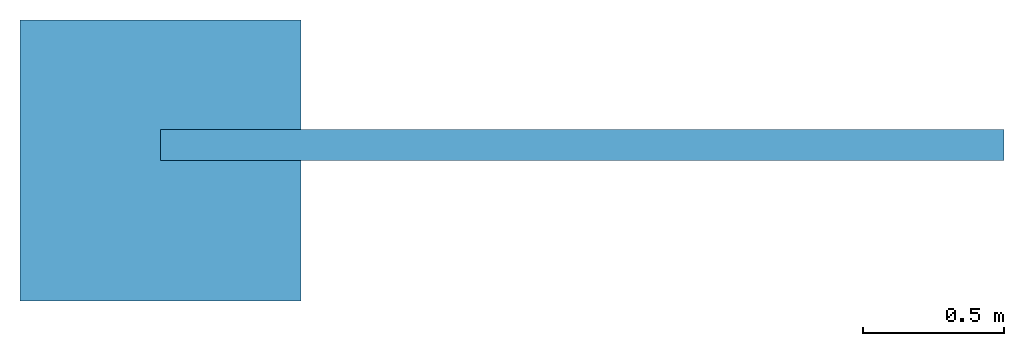
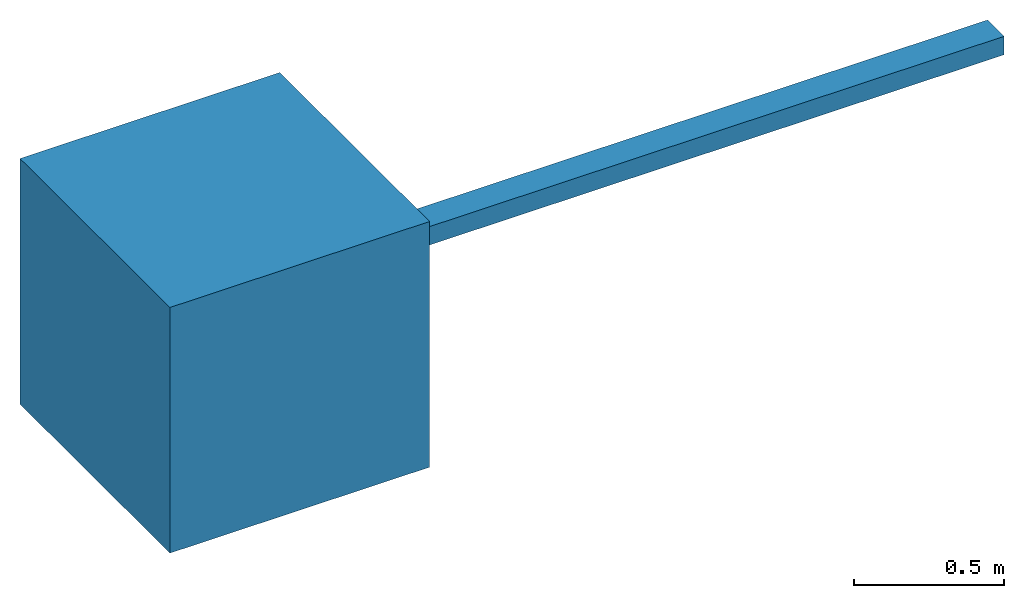
# Not in any storey: 2 beams.
"""IFC4 model written with IfcOpenShell, lengths in millimetres."""

from ifc_helpers import new_model, entity, si_unit, converted_unit, frame, origin_with_axes, origin_2d_with_axis, place, context, subcontext, project, rectangle, extrude, polygons, source, transform, mapped, material, material_profile, profile_set, profile_usage, type_object, type_shapes, element, save


model = new_model("IFC4")

# Units and contexts
model_context = context("Model", 3, precision=1e-05, world=origin_with_axes())
plan_context = context("Plan", 2, precision=1e-05, world=origin_2d_with_axis())
body_context = subcontext(model_context, "Body", "Model", "MODEL_VIEW")
ifc_project = project(units=[si_unit("VOLUMEUNIT", "CUBIC_METRE"), si_unit("LENGTHUNIT", "METRE", prefix="MILLI"), converted_unit("PLANEANGLEUNIT", "degree", entity("IfcReal", 0.0174532925199433), si_unit("PLANEANGLEUNIT", "RADIAN"), dimensions=[0, 0, 0, 0, 0, 0, 0]), si_unit("AREAUNIT", "SQUARE_METRE")], contexts=[model_context, plan_context])

# Beams
ifc_material = material()
ifc_material_profile = material_profile(ifc_material, rectangle(XDim=110.0, YDim=75.0))
ifc_profile_set = profile_set([ifc_material_profile])
ifc_profile_usage = profile_usage(ifc_profile_set, cardinal=3)
beam_type_1 = type_object("IfcBeamType", Name="110x75", PredefinedType="LINTEL", material=ifc_profile_set)
beam_1_placement = place(None, frame((0.0, 0.0, 0.0), z_axis=(0.999999999999994, -7.54979012640429e-08, 7.54979012640429e-08), x_axis=(7.54979012640431e-08, 0.999999999999997, 7.16093850883224e-15)))
element("IfcBeam", 1, at=beam_1_placement, type_object=beam_type_1, material=ifc_profile_usage, Name="Beam", context=body_context, shape_type="SweptSolid", body=[
    extrude(rectangle(XDim=110.0, YDim=75.0), frame((55.0, 37.5, 0.0), z_axis=(0.0, 0.0, 1.0), x_axis=(1.0, 0.0, 0.0)), (0.0, 0.0, 1.0), 3000.0),
])
beam_type_2 = type_object("IfcBeamType", Name="Timber 38x114", PredefinedType="BEAM")
shared_shape = source(origin_with_axes(), body_context, "Body", "Tessellation", [
    polygons([(-499.999969482422, -499.999969482422, -499.999969482422), (-499.999969482422, -499.999969482422, 499.999969482422), (-499.999969482422, 499.999969482422, -499.999969482422), (-499.999969482422, 499.999969482422, 499.999969482422), (499.999969482422, -499.999969482422, -499.999969482422), (499.999969482422, -499.999969482422, 499.999969482422), (499.999969482422, 499.999969482422, -499.999969482422), (499.999969482422, 499.999969482422, 499.999969482422)], [[[1, 2, 4, 3]], [[3, 4, 8, 7]], [[7, 8, 6, 5]], [[5, 6, 2, 1]], [[3, 7, 5, 1]], [[8, 4, 2, 6]]], closed=True),
])
type_shapes(beam_type_2, [shared_shape])
beam_2_placement = place(None, origin_with_axes())
element("IfcBeam", 2, at=beam_2_placement, type_object=beam_type_2, Name="Beam", context=body_context, shape_type="MappedRepresentation", body=[
    mapped(shared_shape, transform((0.0, 0.0, 0.0), x_axis=(1.0, 0.0, 0.0), y_axis=(0.0, 1.0, 0.0), z_axis=(0.0, 0.0, 1.0), scale=1.0)),
])

save(model, "model.ifc")
